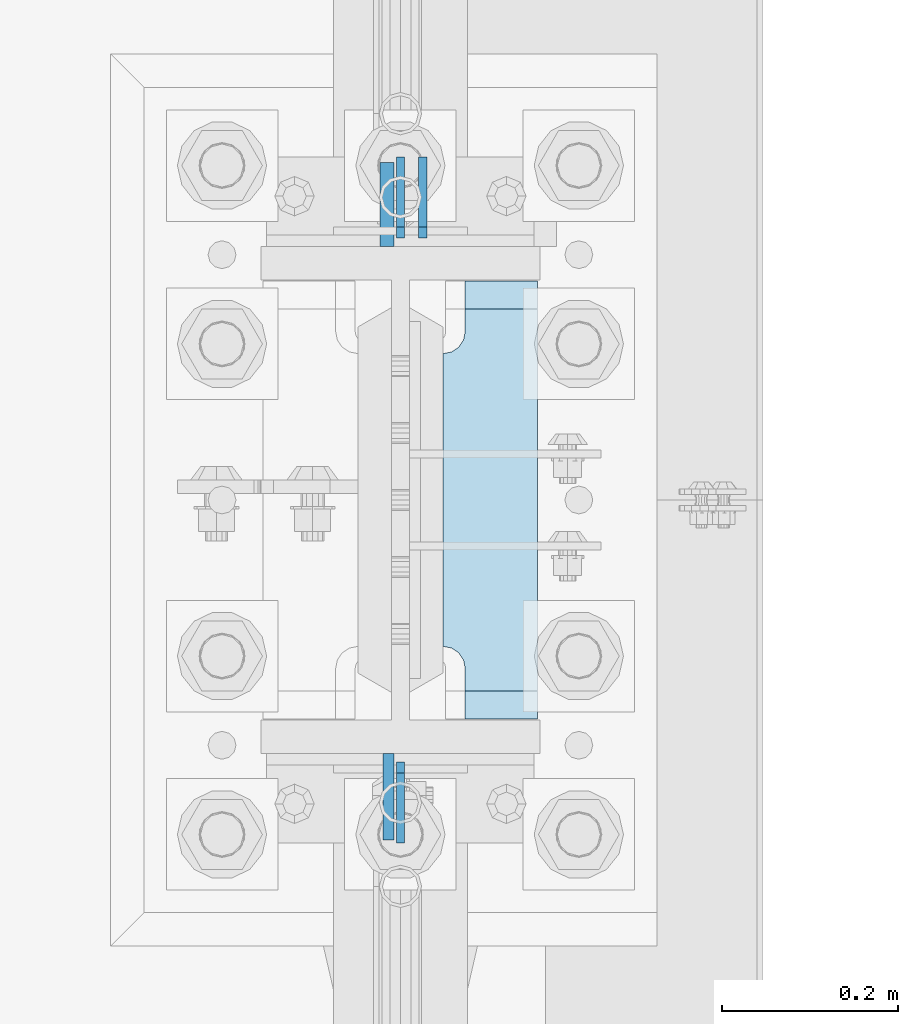
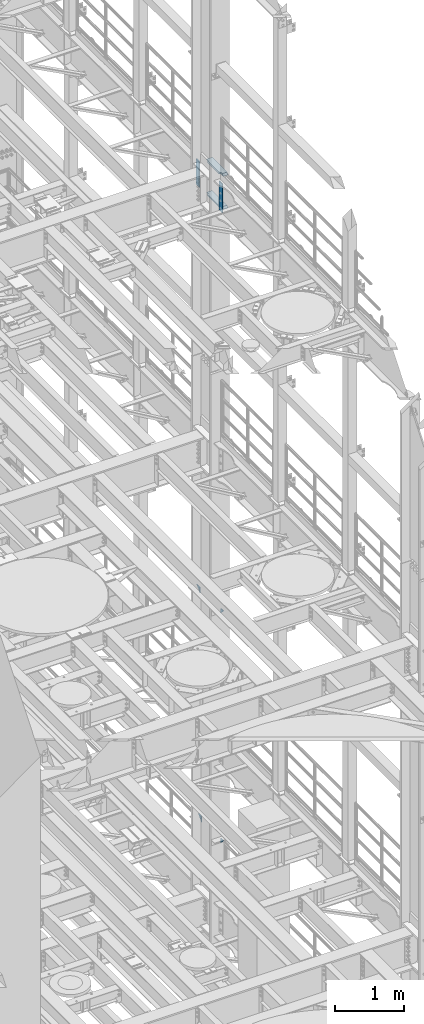
# One storey, part 1814 of 1876: 8 plates, 2 elements without a shape of their own.
"""IFC2X3 building model written with IfcOpenShell, lengths in millimetres."""

from ifc_helpers import new_model, si_unit, frame, origin_with_axes, place, context, subcontext, project, spatial, faceted_brep, material, type_object, element, aggregate, save


model = new_model("IFC2X3")

# Units and contexts
model_context = context("Model", 3, precision=1e-05, world=origin_with_axes())
body_context = subcontext(model_context, "Body", "Model", "MODEL_VIEW")
ifc_project = project(units=[si_unit("LENGTHUNIT", "METRE", prefix="MILLI"), si_unit("AREAUNIT", "SQUARE_METRE"), si_unit("VOLUMEUNIT", "CUBIC_METRE"), si_unit("MASSUNIT", "GRAM", prefix="KILO"), si_unit("TIMEUNIT", "SECOND"), si_unit("PLANEANGLEUNIT", "RADIAN"), si_unit("SOLIDANGLEUNIT", "STERADIAN"), si_unit("THERMODYNAMICTEMPERATUREUNIT", "DEGREE_CELSIUS"), si_unit("LUMINOUSINTENSITYUNIT", "LUMEN")], contexts=[model_context])

# Site, building, storey
site_placement = place(None, origin_with_axes())
site = spatial("IfcSite", under=ifc_project, at=site_placement, CompositionType="ELEMENT")
building_placement = place(site_placement, origin_with_axes())
building = spatial("IfcBuilding", under=site, at=building_placement, Name="Undefined", CompositionType="ELEMENT")
storey_placement = place(building_placement, origin_with_axes())
storey = spatial("IfcBuildingStorey", under=building, at=storey_placement, Name="Undefined", CompositionType="ELEMENT", Elevation=0.0)

# Assembly, plates
assembly_1_placement = place(storey_placement, origin_with_axes())
assembly_1 = element("IfcElementAssembly", 1, at=assembly_1_placement, inside=storey, Name="COLUMN", AssemblyPlace="NOTDEFINED", PredefinedType="RIGID_FRAME")
ifc_material_1 = material(Name="STEEL/A36")
plate_type_1 = type_object("IfcPlateType", PredefinedType="NOTDEFINED")
plate_1_placement = place(assembly_1_placement, frame((7620.0, 8010.52500059683, 10325.1), z_axis=(0.0, -0.707106781186548, 0.707106781186548), x_axis=(0.0, -0.707106781186548, -0.707106781186548)))
plate_1 = element("IfcPlate", 2, at=plate_1_placement, type_object=plate_type_1, material=ifc_material_1, Name="PLATE", context=body_context, shape_type="Brep", body=[
    faceted_brep([(0.0, -4.76249999999982, 0.0), (56.1266013136901, -4.76249999997708, 56.1266013135391), (56.1266013136883, 4.76250000002256, 56.1266013135428), (0.0, 4.76249999999982, 0.0), (74.0871132860975, -4.7624999999698, 56.1266013135246), (74.0871132860993, 4.76250000002983, 56.1266013135282), (130.213714599717, -4.76249999994707, -1.30967237055302e-10), (130.213714599715, 4.76250000005257, -1.23691279441118e-10)], [[[0, 1, 2, 3]], [[1, 4, 5, 2]], [[4, 6, 7, 5]], [[6, 0, 3, 7]], [[5, 7, 3, 2]], [[6, 4, 1, 0]]]),
])
plate_2_placement = place(assembly_1_placement, frame((7620.0, 7229.47499940317, 10325.1), z_axis=(0.0, 0.707106781186548, 0.707106781186548), x_axis=(0.0, 0.707106781186548, -0.707106781186548)))
plate_2 = element("IfcPlate", 3, at=plate_2_placement, type_object=plate_type_1, material=ifc_material_1, Name="PLATE", context=body_context, shape_type="Brep", body=[
    faceted_brep([(0.0, -4.76249999999982, 0.0), (56.1266013136901, -4.76249999997708, 56.1266013135391), (56.1266013136883, 4.76250000002256, 56.1266013135428), (0.0, 4.76249999999982, 0.0), (74.0871132860975, -4.7624999999698, 56.1266013135246), (74.0871132860993, 4.76250000002983, 56.1266013135282), (130.213714599717, -4.76249999994707, -1.30967237055302e-10), (130.213714599715, 4.76250000005257, -1.23691279441118e-10)], [[[0, 1, 2, 3]], [[1, 4, 5, 2]], [[4, 6, 7, 5]], [[6, 0, 3, 7]], [[5, 7, 3, 2]], [[6, 4, 1, 0]]]),
])
plate_3_placement = place(assembly_1_placement, frame((7645.4, 8010.52500059683, 6235.7), z_axis=(0.0, -0.707106781186548, 0.707106781186548), x_axis=(0.0, -0.707106781186548, -0.707106781186548)))
plate_3 = element("IfcPlate", 4, at=plate_3_placement, type_object=plate_type_1, material=ifc_material_1, Name="PLATE", context=body_context, shape_type="Brep", body=[
    faceted_brep([(0.0, -4.76249999999982, 0.0), (56.1266013136901, -4.76249999997708, 56.1266013135391), (56.1266013136883, 4.76250000002256, 56.1266013135428), (0.0, 4.76249999999982, 0.0), (74.0871132860975, -4.7624999999698, 56.1266013135246), (74.0871132860993, 4.76250000002983, 56.1266013135282), (130.213714599717, -4.76249999994707, -1.30967237055302e-10), (130.213714599715, 4.76250000005257, -1.23691279441118e-10)], [[[0, 1, 2, 3]], [[1, 4, 5, 2]], [[4, 6, 7, 5]], [[6, 0, 3, 7]], [[5, 7, 3, 2]], [[6, 4, 1, 0]]]),
])
plate_4_placement = place(assembly_1_placement, frame((7620.0, 7229.47499940317, 6235.7), z_axis=(0.0, 0.707106781186548, 0.707106781186548), x_axis=(0.0, 0.707106781186548, -0.707106781186548)))
plate_4 = element("IfcPlate", 5, at=plate_4_placement, type_object=plate_type_1, material=ifc_material_1, Name="PLATE", context=body_context, shape_type="Brep", body=[
    faceted_brep([(0.0, -4.76249999999982, 0.0), (56.1266013136901, -4.76249999997708, 56.1266013135391), (56.1266013136883, 4.76250000002256, 56.1266013135428), (0.0, 4.76249999999982, 0.0), (74.0871132860975, -4.7624999999698, 56.1266013135246), (74.0871132860993, 4.76250000002983, 56.1266013135282), (130.213714599717, -4.76249999994707, -1.30967237055302e-10), (130.213714599715, 4.76250000005257, -1.23691279441118e-10)], [[[0, 1, 2, 3]], [[1, 4, 5, 2]], [[4, 6, 7, 5]], [[6, 0, 3, 7]], [[5, 7, 3, 2]], [[6, 4, 1, 0]]]),
])
aggregate(assembly_1, [plate_1, plate_2, plate_3, plate_4])

assembly_2_placement = place(storey_placement, origin_with_axes())
assembly_2 = element("IfcElementAssembly", 6, at=assembly_2_placement, inside=storey, Name="COLUMN", AssemblyPlace="NOTDEFINED", PredefinedType="RIGID_FRAME")
ifc_material_2 = material(Name="STEEL/A572-50")
plate_type_2 = type_object("IfcPlateType", PredefinedType="NOTDEFINED")
plate_5_placement = place(assembly_2_placement, frame((7606.50699987411, 7331.075, 17929.225), z_axis=(0.0, -1.0, 0.0), x_axis=(0.0, 0.0, -1.0)))
plate_5 = element("IfcPlate", 7, at=plate_5_placement, type_object=plate_type_2, material=ifc_material_2, Name="PLATE", context=body_context, shape_type="Brep", body=[
    faceted_brep([(0.0, -6.35000000000036, 0.0), (0.0, -6.34999999999991, 98.4250030517578), (0.0, 6.34999999999991, 98.4250030517578), (0.0, 6.35000000000036, 0.0), (514.349975585938, -6.35000000000036, 98.4250030517578), (514.349975585938, 6.35000000000036, 98.4250030517578), (514.349975585938, -6.35000000000036, 0.0), (514.349975585938, 6.35000000000036, 0.0)], [[[0, 1, 2, 3]], [[1, 4, 5, 2]], [[4, 6, 7, 5]], [[6, 0, 3, 7]], [[5, 7, 3, 2]], [[6, 4, 1, 0]]]),
])
plate_type_3 = type_object("IfcPlateType", PredefinedType="NOTDEFINED")
plate_6_placement = place(assembly_2_placement, frame((7604.91949987411, 7908.925, 17919.7), z_axis=(0.0, 1.0, 0.0), x_axis=(0.0, 0.0, -1.0)))
plate_6 = element("IfcPlate", 8, at=plate_6_placement, type_object=plate_type_3, material=ifc_material_2, Name="PLATE", context=body_context, shape_type="Brep", body=[
    faceted_brep([(0.0, -7.9375, 0.0), (0.0, -7.9375, 95.25), (0.0, 7.9375, 95.25), (0.0, 7.9375, 0.0), (457.200012207031, -7.9375, 95.25), (457.200012207031, 7.9375, 95.25), (457.200012207031, -7.9375, 0.0), (457.200012207031, 7.9375, 0.0)], [[[0, 1, 2, 3]], [[1, 4, 5, 2]], [[4, 6, 7, 5]], [[6, 0, 3, 7]], [[5, 7, 3, 2]], [[6, 4, 1, 0]]]),
])
plate_type_4 = type_object("IfcPlateType", PredefinedType="NOTDEFINED")
plate_7_placement = place(assembly_2_placement, frame((7668.41875, 7869.2375, 17376.775012207), z_axis=(0.0, -1.0, 0.0), x_axis=(1.0, 0.0, 0.0)))
plate_7 = element("IfcPlate", 9, at=plate_7_placement, type_object=plate_type_4, material=ifc_material_2, Name="PLATE", context=body_context, shape_type="Brep", body=[
    faceted_brep([(107.949996948242, -15.875, 498.475006103516), (107.949996948242, 15.875, 467.025007631571), (25.3999996185303, 15.875, 467.025007631571), (25.3999996185303, -15.875, 498.475006103516), (23.4665397733561, -15.875, 431.604843634198), (25.3999996185303, -15.875, 441.325002670288), (25.3999996185303, 15.875, 441.325002670288), (23.4665397733561, 15.875, 431.604843634198), (17.9605119724001, -15.875, 423.36449069789), (17.9605119724001, 15.875, 423.36449069789), (9.72015903609281, -15.875, 417.858462896934), (9.72015903609281, 15.875, 417.858462896934), (0.0, -15.875, 415.925003051758), (0.0, 15.875, 415.925003051758), (0.0, -15.875, 82.5500030517578), (0.0, 15.875, 82.5500030517578), (9.72015903609099, -15.875, 80.616543206582), (9.72015903609099, 15.875, 80.616543206582), (17.9605119723983, -15.875, 75.1105154056258), (17.9605119723983, 15.875, 75.1105154056258), (23.4665397733552, -15.875, 66.8701624693183), (23.4665397733552, 15.875, 66.8701624693183), (25.3999996185303, -15.875, 57.1500034332275), (25.3999996185303, 15.875, 57.1500034332275), (25.3999996185303, 15.875, 31.449998471945), (25.3999996185303, -15.875, 0.0), (107.949996948242, 15.875, 31.449998471945), (107.949996948242, -15.875, 0.0)], [[[0, 1, 2, 3]], [[4, 5, 6, 7]], [[8, 4, 7, 9]], [[10, 8, 9, 11]], [[12, 10, 11, 13]], [[14, 12, 13, 15]], [[16, 14, 15, 17]], [[18, 16, 17, 19]], [[20, 18, 19, 21]], [[22, 20, 21, 23]], [[22, 23, 24, 25]], [[26, 27, 25, 24]], [[5, 4, 8, 10, 12, 14, 16, 18, 20, 22, 25, 27, 0, 3]], [[6, 5, 3, 2]], [[26, 24, 23, 21, 19, 17, 15, 13, 11, 9, 7, 6, 2, 1]], [[27, 26, 1, 0]]]),
])
plate_8_placement = place(assembly_2_placement, frame((7668.41875, 7869.2375, 17967.325), z_axis=(0.0, -1.0, 0.0), x_axis=(1.0, 0.0, 0.0)))
plate_8 = element("IfcPlate", 10, at=plate_8_placement, type_object=plate_type_4, material=ifc_material_2, Name="PLATE", context=body_context, shape_type="Brep", body=[
    faceted_brep([(107.949996948242, -15.875, 498.475006103516), (107.949996948242, 15.875, 467.025007631571), (25.3999996185303, 15.875, 467.025007631571), (25.3999996185303, -15.875, 498.475006103516), (23.4665397733561, -15.875, 431.604843634198), (25.3999996185303, -15.875, 441.325002670288), (25.3999996185303, 15.875, 441.325002670288), (23.4665397733561, 15.875, 431.604843634198), (17.9605119724001, -15.875, 423.36449069789), (17.9605119724001, 15.875, 423.36449069789), (9.72015903609281, -15.875, 417.858462896934), (9.72015903609281, 15.875, 417.858462896934), (0.0, -15.875, 415.925003051758), (0.0, 15.875, 415.925003051758), (0.0, -15.875, 82.5500030517578), (0.0, 15.875, 82.5500030517578), (9.72015903609099, -15.875, 80.616543206582), (9.72015903609099, 15.875, 80.616543206582), (17.9605119723983, -15.875, 75.1105154056258), (17.9605119723983, 15.875, 75.1105154056258), (23.4665397733552, -15.875, 66.8701624693183), (23.4665397733552, 15.875, 66.8701624693183), (25.3999996185303, -15.875, 57.1500034332275), (25.3999996185303, 15.875, 57.1500034332275), (25.3999996185303, 15.875, 31.449998471945), (25.3999996185303, -15.875, 0.0), (107.949996948242, 15.875, 31.449998471945), (107.949996948242, -15.875, 0.0)], [[[0, 1, 2, 3]], [[4, 5, 6, 7]], [[8, 4, 7, 9]], [[10, 8, 9, 11]], [[12, 10, 11, 13]], [[14, 12, 13, 15]], [[16, 14, 15, 17]], [[18, 16, 17, 19]], [[20, 18, 19, 21]], [[22, 20, 21, 23]], [[22, 23, 24, 25]], [[26, 27, 25, 24]], [[5, 4, 8, 10, 12, 14, 16, 18, 20, 22, 25, 27, 0, 3]], [[6, 5, 3, 2]], [[26, 24, 23, 21, 19, 17, 15, 13, 11, 9, 7, 6, 2, 1]], [[27, 26, 1, 0]]]),
])
aggregate(assembly_2, [plate_5, plate_6, plate_7, plate_8])

save(model, "model.ifc")
